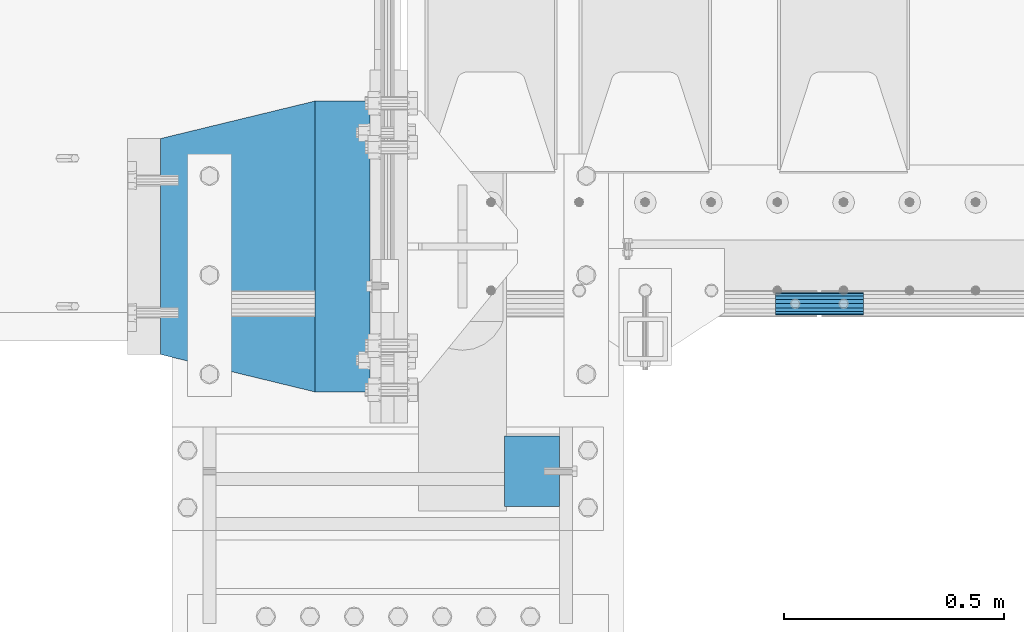
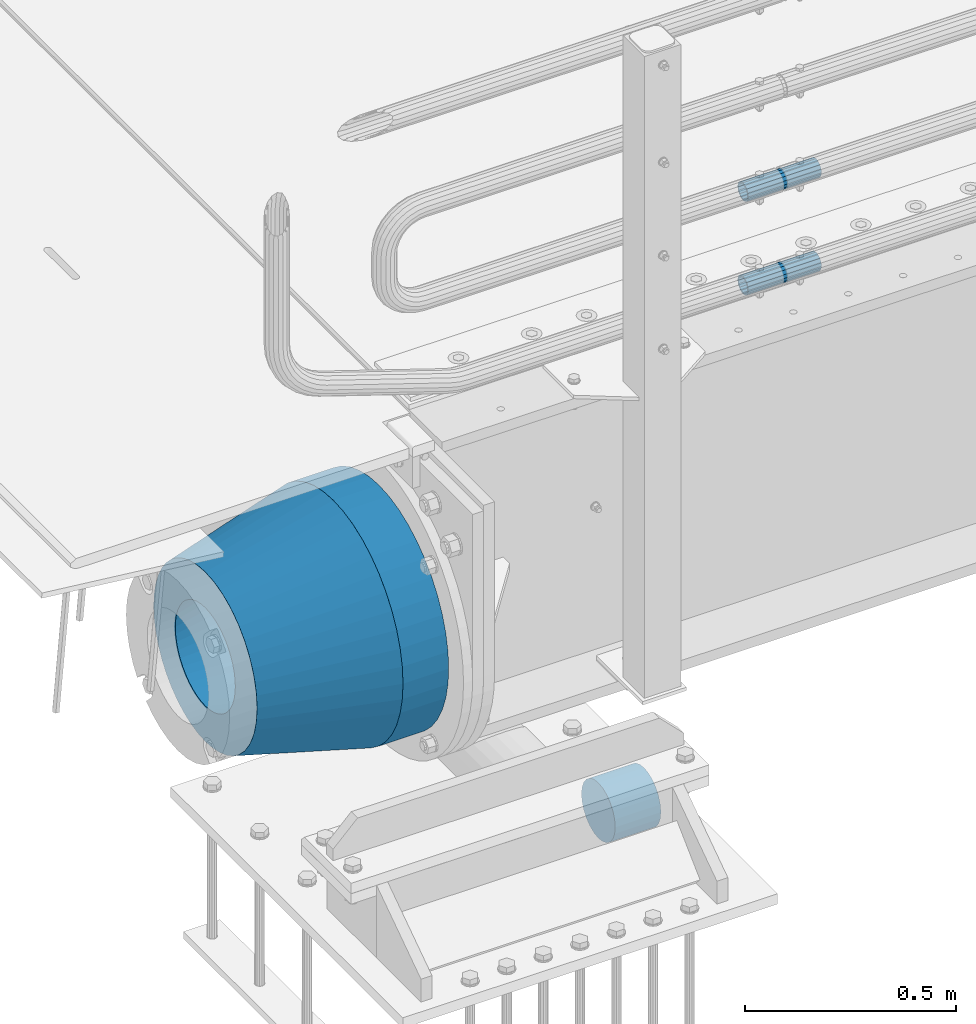
# One storey, part 105 of 193: 5 beams.
"""IFC2X3 building model written with IfcOpenShell, lengths in millimetres."""

import ifcopenshell
import ifcopenshell.guid

model = None  # the IFC model being written
_history = None  # IfcOwnerHistory: only IFC2X3 demands one
_inside = {}  # id of a spatial element -> (the spatial element, [elements in it])
_under = {}  # id of a project, library or spatial element -> (it, [spatial elements below it])
_declared = {}  # id of a project -> (the project, [libraries it declares])
_typed = {}  # id of a type object -> (the type object, [elements of that type])
_made_of = {}  # id of a material, layer set ... -> (it, [elements and type objects made of it])


def new_model(schema):
    """Start an empty IFC model of exactly this schema.

    Asked for "IFC4X3", IfcOpenShell would pick the latest addendum, in which some entities
    have other attributes; the version numbers below select the first issue.
    IFC2X3 requires an IfcOwnerHistory on every rooted entity: one is made here for all.
    """
    global model, _history
    if schema == "IFC4X3":
        model = ifcopenshell.file(schema_version=(4, 3, 0, 0))
    else:
        model = ifcopenshell.file(schema=schema)
    _inside.clear()
    _under.clear()
    _declared.clear()
    _typed.clear()
    _made_of.clear()
    _history = None
    if model.schema == "IFC2X3":
        org = make("IfcOrganization", Name="unknown")
        user = make(
            "IfcPersonAndOrganization",
            ThePerson=make("IfcPerson", FamilyName="unknown"),
            TheOrganization=org,
        )
        app = make(
            "IfcApplication",
            ApplicationDeveloper=org,
            Version="unknown",
            ApplicationFullName="unknown",
            ApplicationIdentifier="unknown",
        )
        _history = make(
            "IfcOwnerHistory",
            OwningUser=user,
            OwningApplication=app,
            ChangeAction="ADDED",
            CreationDate=0,
        )
    return model


def make(cls, **values):
    """One entity of the class cls with the attributes given. An attribute that is None is left unset."""
    return model.create_entity(
        cls, **{name: value for name, value in values.items() if value is not None}
    )


def rooted(cls, **values):
    """An entity with a GlobalId (a new one), such as an element, a storey or a relation."""
    return make(cls, GlobalId=ifcopenshell.guid.new(), OwnerHistory=_history, **values)


def si_unit(unit_type, name, prefix=None):
    """IfcSIUnit, for example si_unit("LENGTHUNIT", "METRE", prefix="MILLI")."""
    return make("IfcSIUnit", UnitType=unit_type, Prefix=prefix, Name=name)


def assignment(units):
    """IfcUnitAssignment: the units of a project."""
    return None if units is None else make("IfcUnitAssignment", Units=units)


def point(xyz):
    """IfcCartesianPoint."""
    return None if xyz is None else make("IfcCartesianPoint", Coordinates=xyz)


def direction(xyz):
    """IfcDirection."""
    return None if xyz is None else make("IfcDirection", DirectionRatios=xyz)


def frame(location, z_axis=None, x_axis=None):
    """IfcAxis2Placement3D, a coordinate frame: its origin and axes. An axis left out is left unset."""
    return make(
        "IfcAxis2Placement3D",
        Location=point(location),
        Axis=direction(z_axis),
        RefDirection=direction(x_axis),
    )


def origin_with_axes():
    """The frame at (0, 0, 0) with the z axis (0, 0, 1) and the x axis (1, 0, 0) written out."""
    return frame((0.0, 0.0, 0.0), z_axis=(0.0, 0.0, 1.0), x_axis=(1.0, 0.0, 0.0))


def place(relative_to, where):
    """IfcLocalPlacement: puts the frame where relative to a parent placement (None: the world)."""
    return make(
        "IfcLocalPlacement", PlacementRelTo=relative_to, RelativePlacement=where
    )


def context(
    kind, dimensions, precision=None, world=None, true_north=None, identifier=None
):
    """IfcGeometricRepresentationContext, for example the 3D "Model" context."""
    return make(
        "IfcGeometricRepresentationContext",
        ContextIdentifier=identifier,
        ContextType=kind,
        CoordinateSpaceDimension=dimensions,
        Precision=precision,
        WorldCoordinateSystem=world,
        TrueNorth=true_north,
    )


def subcontext(parent, identifier, kind, view, scale=None):
    """IfcGeometricRepresentationSubContext, for example "Body" below "Model"."""
    return make(
        "IfcGeometricRepresentationSubContext",
        ContextIdentifier=identifier,
        ContextType=kind,
        ParentContext=parent,
        TargetScale=scale,
        TargetView=view,
    )


def project(units=None, contexts=None):
    """IfcProject with its units and contexts."""
    return rooted(
        "IfcProject",
        Name="project",
        RepresentationContexts=contexts,
        UnitsInContext=assignment(units),
    )


def spatial(cls, under=None, at=None, **own):
    """A site, building, storey or space (cls), placed at a placement, below another one or the project."""
    s = rooted(cls, ObjectPlacement=at, **own)
    if under is not None:
        _under.setdefault(under.id(), (under, []))[1].append(s)
    return s


def faces_of(points, faces, orient=None, outer=None):
    """IfcFace entities. A face is a list of loops; a loop is a list of indices into points, from 0.

    orient and outer hold one flag for each loop. By default every Orientation is true, the
    first loop of a face is its IfcFaceOuterBound and the others are IfcFaceBound.
    """
    made = []
    for i, loops in enumerate(faces):
        bounds = []
        for j, loop in enumerate(loops):
            is_outer = j == 0 if outer is None else outer[i][j]
            bounds.append(
                make(
                    "IfcFaceOuterBound" if is_outer else "IfcFaceBound",
                    Bound=make("IfcPolyLoop", Polygon=[points[k] for k in loop]),
                    Orientation=True if orient is None else orient[i][j],
                )
            )
        made.append(make("IfcFace", Bounds=bounds))
    return made


def faceted_brep(points, faces, orient=None, outer=None, voids=None):
    """IfcFacetedBrep: a solid bounded by flat faces; with voids (closed shells), ...WithVoids."""
    shared = [point(p) for p in points]
    hull = make("IfcClosedShell", CfsFaces=faces_of(shared, faces, orient, outer))
    if voids is None:
        return make("IfcFacetedBrep", Outer=hull)
    return make(
        "IfcFacetedBrepWithVoids",
        Outer=hull,
        Voids=[
            make(cls, CfsFaces=faces_of(shared, fs, o, b)) for cls, fs, o, b in voids
        ],
    )


def shape(context_of_items, identifier, shape_type, items):
    """IfcShapeRepresentation: the items that make up one representation, for example the "Body"."""
    return make(
        "IfcShapeRepresentation",
        ContextOfItems=context_of_items,
        RepresentationIdentifier=identifier,
        RepresentationType=shape_type,
        Items=items,
    )


def material(Name=None, Category=None):
    """IfcMaterial."""
    return make("IfcMaterial", Name=Name, Category=Category)


def made_of(thing, what):
    """Note that an element or type object is made of a material, layer set ...; save() writes the relation."""
    if what is not None:
        _made_of.setdefault(what.id(), (what, []))[1].append(thing)
    return thing


def type_object(cls, material=None, **own):
    """A type object (cls), such as IfcWallType, which elements share."""
    return made_of(rooted(cls, **own), material)


def element(
    cls,
    number,
    at=None,
    inside=None,
    cuts=None,
    type_object=None,
    material=None,
    context=None,
    identifier="Body",
    shape_type=None,
    held_by="IfcProductDefinitionShape",
    body=None,
    shapes=None,
    **own,
):
    """One element of the class cls, such as IfcWall. Its Tag is "e" and its number.

    at: its placement. inside: the storey or other place that contains it. cuts: it is an
    opening in that element (IfcRelVoidsElement). A single representation is given by context,
    identifier, shape_type and body (its items); several are given by shapes. held_by: the class
    of the entity that holds the representations. save() writes the other relations.
    """
    e = rooted(cls, Tag="e%d" % number, ObjectPlacement=at, **own)
    if body is not None:
        shapes = [shape(context, identifier, shape_type, body)]
    if shapes is not None:
        e.Representation = make(held_by, Representations=shapes)
    if inside is not None:
        _inside.setdefault(inside.id(), (inside, []))[1].append(e)
    if cuts is not None:
        rooted(
            "IfcRelVoidsElement", RelatingBuildingElement=cuts, RelatedOpeningElement=e
        )
    if type_object is not None:
        _typed.setdefault(type_object.id(), (type_object, []))[1].append(e)
    return made_of(e, material)


def aggregate(whole, parts):
    """IfcRelAggregates: a whole, such as a stair, and the parts it consists of."""
    return rooted("IfcRelAggregates", RelatingObject=whole, RelatedObjects=parts)


def save(model, path):
    """Write the relations noted so far, then the file.

    IfcRelAggregates (storeys below a building ...), IfcRelContainedInSpatialStructure (elements
    in a storey), IfcRelDefinesByType, IfcRelAssociatesMaterial and IfcRelDeclares: one each for
    every whole, place, type object, material and project.
    """
    for whole, parts in _under.values():
        aggregate(whole, parts)
    for where, things in _inside.values():
        rooted(
            "IfcRelContainedInSpatialStructure",
            RelatedElements=things,
            RelatingStructure=where,
        )
    for kind, things in _typed.values():
        rooted("IfcRelDefinesByType", RelatedObjects=things, RelatingType=kind)
    for what, things in _made_of.values():
        rooted("IfcRelAssociatesMaterial", RelatedObjects=things, RelatingMaterial=what)
    for by, libraries in _declared.values():
        rooted("IfcRelDeclares", RelatingContext=by, RelatedDefinitions=libraries)
    model.write(path)


model = new_model("IFC2X3")

# Units and contexts
model_context = context("Model", 3, precision=1e-05, world=origin_with_axes())
body_context = subcontext(model_context, "Body", "Model", "MODEL_VIEW")
ifc_project = project(units=[si_unit("LENGTHUNIT", "METRE", prefix="MILLI"), si_unit("AREAUNIT", "SQUARE_METRE"), si_unit("VOLUMEUNIT", "CUBIC_METRE"), si_unit("MASSUNIT", "GRAM", prefix="KILO"), si_unit("TIMEUNIT", "SECOND"), si_unit("PLANEANGLEUNIT", "RADIAN"), si_unit("SOLIDANGLEUNIT", "STERADIAN"), si_unit("THERMODYNAMICTEMPERATUREUNIT", "DEGREE_CELSIUS"), si_unit("LUMINOUSINTENSITYUNIT", "LUMEN")], contexts=[model_context])

# Site, building, storey
site_placement = place(None, origin_with_axes())
site = spatial("IfcSite", under=ifc_project, at=site_placement, CompositionType="ELEMENT")
building_placement = place(site_placement, origin_with_axes())
building = spatial("IfcBuilding", under=site, at=building_placement, Name="Standard", CompositionType="ELEMENT")
storey_placement = place(building_placement, origin_with_axes())
storey = spatial("IfcBuildingStorey", under=building, at=storey_placement, Name="Undefined", CompositionType="ELEMENT", Elevation=0.0)

# Beams
ifc_material_1 = material()
beam_type_1 = type_object("IfcBeamType", PredefinedType="NOTDEFINED")
beam_1_placement = place(storey_placement, frame((-42219.9999999991, 23490.000000001, -923.000000000004), z_axis=(0.0, 0.0, -1.0), x_axis=(1.0, 0.0, 0.0)))
element("IfcBeam", 1, at=beam_1_placement, inside=storey, type_object=beam_type_1, material=ifc_material_1, context=body_context, shape_type="Brep", body=[
    faceted_brep([(0.0, -80.0, 0.0), (0.0, -77.2740661031239, -20.7055236082017), (125.0, -77.2740661031239, -20.7055236082017), (125.0, -80.0, 0.0), (0.0, -69.2820323027554, -40.0), (125.0, -69.2820323027554, -40.0), (0.0, -56.5685424949224, -56.5685424949238), (125.0, -56.5685424949224, -56.5685424949238), (0.0, -40.0, -69.2820323027552), (125.0, -40.0, -69.2820323027552), (0.0, -20.7055236082015, -77.2740661031255), (125.0, -20.7055236082015, -77.2740661031255), (0.0, 0.0, -80.0), (125.0, 0.0, -80.0), (0.0, 20.7055236082015, -77.2740661031255), (125.0, 20.7055236082015, -77.2740661031255), (0.0, 40.0, -69.2820323027551), (125.0, 40.0, -69.2820323027551), (0.0, 56.5685424949224, -56.5685424949238), (125.0, 56.5685424949224, -56.5685424949238), (0.0, 69.2820323027554, -40.0), (125.0, 69.2820323027554, -40.0), (0.0, 77.2740661031239, -20.7055236082016), (125.0, 77.2740661031239, -20.7055236082016), (0.0, 80.0, 0.0), (125.0, 80.0, 0.0), (0.0, 77.2740661031239, 20.7055236082017), (125.0, 77.2740661031239, 20.7055236082017), (0.0, 69.2820323027554, 40.0), (125.0, 69.2820323027554, 40.0), (0.0, 56.5685424949224, 56.5685424949238), (125.0, 56.5685424949224, 56.5685424949238), (0.0, 40.0, 69.2820323027551), (125.0, 40.0, 69.2820323027551), (0.0, 20.7055236082015, 77.2740661031255), (125.0, 20.7055236082015, 77.2740661031255), (0.0, 0.0, 80.0), (125.0, 0.0, 80.0), (0.0, -20.7055236082015, 77.2740661031255), (125.0, -20.7055236082015, 77.2740661031255), (0.0, -40.0, 69.2820323027551), (125.0, -40.0, 69.2820323027551), (0.0, -56.5685424949224, 56.5685424949238), (125.0, -56.5685424949224, 56.5685424949238), (0.0, -69.2820323027554, 40.0), (125.0, -69.2820323027554, 40.0), (0.0, -77.2740661031239, 20.7055236082017), (125.0, -77.2740661031239, 20.7055236082017)], [[[0, 1, 2, 3]], [[1, 4, 5, 2]], [[4, 6, 7, 5]], [[6, 8, 9, 7]], [[8, 10, 11, 9]], [[10, 12, 13, 11]], [[12, 14, 15, 13]], [[14, 16, 17, 15]], [[16, 18, 19, 17]], [[18, 20, 21, 19]], [[20, 22, 23, 21]], [[22, 24, 25, 23]], [[24, 26, 27, 25]], [[26, 28, 29, 27]], [[28, 30, 31, 29]], [[30, 32, 33, 31]], [[32, 34, 35, 33]], [[34, 36, 37, 35]], [[36, 38, 39, 37]], [[38, 40, 41, 39]], [[40, 42, 43, 41]], [[42, 44, 45, 43]], [[44, 46, 47, 45]], [[46, 0, 3, 47]], [[5, 7, 9, 11, 13, 15, 17, 19, 21, 23, 25, 27, 29, 31, 33, 35, 37, 39, 41, 43, 45, 47, 3, 2]], [[46, 44, 42, 40, 38, 36, 34, 32, 30, 28, 26, 24, 22, 20, 18, 16, 14, 12, 10, 8, 6, 4, 1, 0]]]),
])
ifc_material_2 = material()
beam_type_2 = type_object("IfcBeamType", PredefinedType="NOTDEFINED")
beam_2_placement = place(storey_placement, frame((-41605.0024970001, 23870.1500000004, 149.849999999747), z_axis=(0.0, 0.0, 1.0), x_axis=(1.0, 0.0, 0.0)))
element("IfcBeam", 2, at=beam_2_placement, inside=storey, type_object=beam_type_2, material=ifc_material_2, context=body_context, shape_type="Brep", body=[
    faceted_brep([(0.0, -21.9000000000015, 0.0), (0.0, -20.232961761998, 8.38076716879547), (200.0, -20.232961761998, 8.38076716879547), (200.0, -21.9000000000015, 0.0), (0.0, -15.4856385079838, 15.4856385079854), (200.0, -15.4856385079838, 15.4856385079854), (0.0, -8.38076716879368, 20.2329617619972), (200.0, -8.38076716879368, 20.2329617619972), (0.0, 0.0, 21.9), (200.0, 0.0, 21.9), (0.0, 8.38076716879368, 20.2329617619972), (200.0, 8.38076716879368, 20.2329617619972), (0.0, 15.4856385079838, 15.4856385079854), (200.0, 15.4856385079838, 15.4856385079854), (0.0, 20.232961761998, 8.38076716879547), (200.0, 20.232961761998, 8.38076716879547), (0.0, 21.9000000000015, 0.0), (200.0, 21.9000000000015, 0.0), (0.0, 20.232961761998, -8.38076716879547), (200.0, 20.232961761998, -8.38076716879547), (0.0, 15.4856385079838, -15.4856385079854), (200.0, 15.4856385079838, -15.4856385079854), (0.0, 8.38076716879368, -20.2329617619972), (200.0, 8.38076716879368, -20.2329617619972), (0.0, 0.0, -21.9), (200.0, 0.0, -21.9), (0.0, -8.38076716879368, -20.2329617619972), (200.0, -8.38076716879368, -20.2329617619972), (0.0, -15.4856385079838, -15.4856385079854), (200.0, -15.4856385079838, -15.4856385079854), (0.0, -20.232961761998, -8.38076716879547), (200.0, -20.232961761998, -8.38076716879547), (0.0, -25.5, 0.0), (0.0, -23.5589280790373, -9.7584275253098), (200.0, -23.5589280790373, -9.7584275253098), (200.0, -25.5, 0.0), (0.0, -18.0312229202573, -18.031222920257), (200.0, -18.0312229202573, -18.031222920257), (0.0, -9.75842752531025, -23.5589280790378), (200.0, -9.75842752531025, -23.5589280790378), (0.0, 0.0, -25.5), (200.0, 0.0, -25.5), (0.0, 9.75842752531025, -23.5589280790378), (200.0, 9.75842752531025, -23.5589280790378), (0.0, 18.0312229202573, -18.031222920257), (200.0, 18.0312229202573, -18.031222920257), (0.0, 23.5589280790373, -9.7584275253098), (200.0, 23.5589280790373, -9.7584275253098), (0.0, 25.5, 0.0), (200.0, 25.5, 0.0), (0.0, 23.5589280790373, 9.7584275253098), (200.0, 23.5589280790373, 9.7584275253098), (0.0, 18.0312229202573, 18.031222920257), (200.0, 18.0312229202573, 18.031222920257), (0.0, 9.75842752531025, 23.5589280790378), (200.0, 9.75842752531025, 23.5589280790378), (0.0, 0.0, 25.5), (200.0, 0.0, 25.5), (0.0, -9.75842752531025, 23.5589280790378), (200.0, -9.75842752531025, 23.5589280790378), (0.0, -18.0312229202573, 18.031222920257), (200.0, -18.0312229202573, 18.031222920257), (0.0, -23.5589280790373, 9.7584275253098), (200.0, -23.5589280790373, 9.7584275253098)], [[[0, 1, 2, 3]], [[1, 4, 5, 2]], [[4, 6, 7, 5]], [[6, 8, 9, 7]], [[8, 10, 11, 9]], [[10, 12, 13, 11]], [[12, 14, 15, 13]], [[14, 16, 17, 15]], [[16, 18, 19, 17]], [[18, 20, 21, 19]], [[20, 22, 23, 21]], [[22, 24, 25, 23]], [[24, 26, 27, 25]], [[26, 28, 29, 27]], [[28, 30, 31, 29]], [[30, 0, 3, 31]], [[32, 33, 34, 35]], [[33, 36, 37, 34]], [[36, 38, 39, 37]], [[38, 40, 41, 39]], [[40, 42, 43, 41]], [[42, 44, 45, 43]], [[44, 46, 47, 45]], [[46, 48, 49, 47]], [[48, 50, 51, 49]], [[50, 52, 53, 51]], [[52, 54, 55, 53]], [[54, 56, 57, 55]], [[56, 58, 59, 57]], [[58, 60, 61, 59]], [[60, 62, 63, 61]], [[62, 32, 35, 63]], [[37, 39, 41, 43, 45, 47, 49, 51, 53, 55, 57, 59, 61, 63, 35, 34], [5, 7, 9, 11, 13, 15, 17, 19, 21, 23, 25, 27, 29, 31, 3, 2]], [[62, 60, 58, 56, 54, 52, 50, 48, 46, 44, 42, 40, 38, 36, 33, 32], [30, 28, 26, 24, 22, 20, 18, 16, 14, 12, 10, 8, 6, 4, 1, 0]]]),
])
beam_3_placement = place(storey_placement, frame((-41605.0024970001, 23870.1500000004, 420.149999999747), z_axis=(0.0, 0.0, 1.0), x_axis=(1.0, 0.0, 0.0)))
element("IfcBeam", 3, at=beam_3_placement, inside=storey, type_object=beam_type_2, material=ifc_material_2, context=body_context, shape_type="Brep", body=[
    faceted_brep([(0.0, -21.9000000000015, 0.0), (0.0, -20.232961761998, 8.38076716879547), (200.0, -20.232961761998, 8.38076716879547), (200.0, -21.9000000000015, 0.0), (0.0, -15.4856385079838, 15.4856385079854), (200.0, -15.4856385079838, 15.4856385079854), (0.0, -8.38076716879368, 20.2329617619972), (200.0, -8.38076716879368, 20.2329617619972), (0.0, 0.0, 21.9), (200.0, 0.0, 21.9), (0.0, 8.38076716879368, 20.2329617619972), (200.0, 8.38076716879368, 20.2329617619972), (0.0, 15.4856385079838, 15.4856385079854), (200.0, 15.4856385079838, 15.4856385079854), (0.0, 20.232961761998, 8.38076716879547), (200.0, 20.232961761998, 8.38076716879547), (0.0, 21.9000000000015, 0.0), (200.0, 21.9000000000015, 0.0), (0.0, 20.232961761998, -8.38076716879547), (200.0, 20.232961761998, -8.38076716879547), (0.0, 15.4856385079838, -15.4856385079854), (200.0, 15.4856385079838, -15.4856385079854), (0.0, 8.38076716879368, -20.2329617619972), (200.0, 8.38076716879368, -20.2329617619972), (0.0, 0.0, -21.9), (200.0, 0.0, -21.9), (0.0, -8.38076716879368, -20.2329617619972), (200.0, -8.38076716879368, -20.2329617619972), (0.0, -15.4856385079838, -15.4856385079854), (200.0, -15.4856385079838, -15.4856385079854), (0.0, -20.232961761998, -8.38076716879547), (200.0, -20.232961761998, -8.38076716879547), (0.0, -25.5, 0.0), (0.0, -23.5589280790373, -9.7584275253098), (200.0, -23.5589280790373, -9.7584275253098), (200.0, -25.5, 0.0), (0.0, -18.0312229202573, -18.031222920257), (200.0, -18.0312229202573, -18.031222920257), (0.0, -9.75842752531025, -23.5589280790378), (200.0, -9.75842752531025, -23.5589280790378), (0.0, 0.0, -25.5), (200.0, 0.0, -25.5), (0.0, 9.75842752531025, -23.5589280790378), (200.0, 9.75842752531025, -23.5589280790378), (0.0, 18.0312229202573, -18.031222920257), (200.0, 18.0312229202573, -18.031222920257), (0.0, 23.5589280790373, -9.7584275253098), (200.0, 23.5589280790373, -9.7584275253098), (0.0, 25.5, 0.0), (200.0, 25.5, 0.0), (0.0, 23.5589280790373, 9.7584275253098), (200.0, 23.5589280790373, 9.7584275253098), (0.0, 18.0312229202573, 18.031222920257), (200.0, 18.0312229202573, 18.031222920257), (0.0, 9.75842752531025, 23.5589280790378), (200.0, 9.75842752531025, 23.5589280790378), (0.0, 0.0, 25.5), (200.0, 0.0, 25.5), (0.0, -9.75842752531025, 23.5589280790378), (200.0, -9.75842752531025, 23.5589280790378), (0.0, -18.0312229202573, 18.031222920257), (200.0, -18.0312229202573, 18.031222920257), (0.0, -23.5589280790373, 9.7584275253098), (200.0, -23.5589280790373, 9.7584275253098)], [[[0, 1, 2, 3]], [[1, 4, 5, 2]], [[4, 6, 7, 5]], [[6, 8, 9, 7]], [[8, 10, 11, 9]], [[10, 12, 13, 11]], [[12, 14, 15, 13]], [[14, 16, 17, 15]], [[16, 18, 19, 17]], [[18, 20, 21, 19]], [[20, 22, 23, 21]], [[22, 24, 25, 23]], [[24, 26, 27, 25]], [[26, 28, 29, 27]], [[28, 30, 31, 29]], [[30, 0, 3, 31]], [[32, 33, 34, 35]], [[33, 36, 37, 34]], [[36, 38, 39, 37]], [[38, 40, 41, 39]], [[40, 42, 43, 41]], [[42, 44, 45, 43]], [[44, 46, 47, 45]], [[46, 48, 49, 47]], [[48, 50, 51, 49]], [[50, 52, 53, 51]], [[52, 54, 55, 53]], [[54, 56, 57, 55]], [[56, 58, 59, 57]], [[58, 60, 61, 59]], [[60, 62, 63, 61]], [[62, 32, 35, 63]], [[37, 39, 41, 43, 45, 47, 49, 51, 53, 55, 57, 59, 61, 63, 35, 34], [5, 7, 9, 11, 13, 15, 17, 19, 21, 23, 25, 27, 29, 31, 3, 2]], [[62, 60, 58, 56, 54, 52, 50, 48, 46, 44, 42, 40, 38, 36, 33, 32], [30, 28, 26, 24, 22, 20, 18, 16, 14, 12, 10, 8, 6, 4, 1, 0]]]),
])
ifc_material_3 = material(Name="STEEL/S355N")
beam_type_3 = type_object("IfcBeamType", PredefinedType="NOTDEFINED")
beam_4_placement = place(storey_placement, frame((-42525.0, 24000.0, -515.0), z_axis=(0.0, 0.0, 1.0), x_axis=(-1.0, 0.0, 0.0)))
element("IfcBeam", 4, at=beam_4_placement, inside=storey, type_object=beam_type_3, material=ifc_material_3, context=body_context, shape_type="Brep", body=[
    faceted_brep([(0.0, -215.0, 0.0), (0.0, -212.811610004399, 30.5976902287563), (125.0, -212.811610004399, 30.5976902287563), (125.0, -215.0, 0.0), (0.0, -206.290989327117, 60.5724997209074), (125.0, -206.290989327117, 60.5724997209074), (0.0, -195.570879001221, 89.3142277954056), (125.0, -195.570879001221, 89.3142277954056), (0.0, -180.869509558703, 116.237775752953), (125.0, -180.869509558703, 116.237775752953), (0.0, -162.486158486165, 140.795057798236), (125.0, -162.486158486165, 140.795057798236), (0.0, -140.795057798237, 162.486158486165), (125.0, -140.795057798237, 162.486158486165), (0.0, -116.237775752954, 180.869509558704), (125.0, -116.237775752954, 180.869509558704), (0.0, -89.3142277954066, 195.570879001222), (125.0, -89.3142277954066, 195.570879001222), (0.0, -60.5724997209072, 206.290989327117), (125.0, -60.5724997209072, 206.290989327117), (0.0, -30.5976902287548, 212.811610004401), (125.0, -30.5976902287548, 212.811610004401), (0.0, 0.0, 215.0), (125.0, 0.0, 215.0), (0.0, 30.5976902287548, 212.811610004401), (125.0, 30.5976902287548, 212.811610004401), (0.0, 60.5724997209072, 206.290989327117), (125.0, 60.5724997209072, 206.290989327117), (0.0, 89.3142277954066, 195.570879001221), (125.0, 89.3142277954066, 195.570879001221), (0.0, 116.237775752954, 180.869509558704), (125.0, 116.237775752954, 180.869509558704), (0.0, 140.795057798237, 162.486158486165), (125.0, 140.795057798237, 162.486158486165), (0.0, 162.486158486165, 140.795057798236), (125.0, 162.486158486165, 140.795057798236), (0.0, 180.869509558703, 116.237775752953), (125.0, 180.869509558703, 116.237775752953), (0.0, 195.570879001221, 89.3142277954056), (125.0, 195.570879001221, 89.3142277954056), (0.0, 206.290989327117, 60.5724997209073), (125.0, 206.290989327117, 60.5724997209073), (0.0, 212.811610004399, 30.5976902287563), (125.0, 212.811610004399, 30.5976902287563), (0.0, 215.0, 0.0), (125.0, 215.0, 0.0), (0.0, 212.811610004399, -30.5976902287563), (125.0, 212.811610004399, -30.5976902287563), (0.0, 206.290989327117, -60.5724997209073), (125.0, 206.290989327117, -60.5724997209073), (0.0, 195.570879001221, -89.3142277954056), (125.0, 195.570879001221, -89.3142277954056), (0.0, 180.869509558703, -116.237775752954), (125.0, 180.869509558703, -116.237775752954), (0.0, 162.486158486165, -140.795057798236), (125.0, 162.486158486165, -140.795057798236), (0.0, 140.795057798237, -162.486158486166), (125.0, 140.795057798237, -162.486158486166), (0.0, 116.237775752954, -180.869509558704), (125.0, 116.237775752954, -180.869509558704), (0.0, 89.3142277954066, -195.570879001221), (125.0, 89.3142277954066, -195.570879001221), (0.0, 60.5724997209072, -206.290989327117), (125.0, 60.5724997209072, -206.290989327117), (0.0, 30.5976902287548, -212.811610004401), (125.0, 30.5976902287548, -212.811610004401), (0.0, 0.0, -215.0), (125.0, 0.0, -215.0), (0.0, -30.5976902287548, -212.811610004401), (125.0, -30.5976902287548, -212.811610004401), (0.0, -60.5724997209072, -206.290989327117), (125.0, -60.5724997209072, -206.290989327117), (0.0, -89.3142277954066, -195.570879001221), (125.0, -89.3142277954066, -195.570879001221), (0.0, -116.237775752954, -180.869509558704), (125.0, -116.237775752954, -180.869509558704), (0.0, -140.795057798237, -162.486158486166), (125.0, -140.795057798237, -162.486158486166), (0.0, -162.486158486165, -140.795057798236), (125.0, -162.486158486165, -140.795057798236), (0.0, -180.869509558703, -116.237775752953), (125.0, -180.869509558703, -116.237775752953), (0.0, -195.570879001221, -89.3142277954056), (125.0, -195.570879001221, -89.3142277954056), (0.0, -206.290989327117, -60.5724997209073), (125.0, -206.290989327117, -60.5724997209073), (0.0, -212.811610004399, -30.5976902287563), (125.0, -212.811610004399, -30.5976902287563), (0.0, -330.0, 0.0), (0.0, -326.641075820709, -46.9638966301842), (125.0, -326.641075820709, -46.9638966301842), (125.0, -330.0, 0.0), (0.0, -316.632681292784, -92.9717437576718), (125.0, -316.632681292784, -92.9717437576718), (0.0, -300.178558466992, -137.086954290623), (125.0, -300.178558466992, -137.086954290623), (0.0, -277.613665834291, -178.411469760347), (125.0, -277.613665834291, -178.411469760347), (0.0, -249.397359536906, -216.104042201944), (125.0, -249.397359536906, -216.104042201944), (0.0, -216.104042201943, -249.397359536905), (125.0, -216.104042201943, -249.397359536905), (0.0, -178.411469760347, -277.61366583429), (125.0, -178.411469760347, -277.61366583429), (0.0, -137.086954290622, -300.178558466991), (125.0, -137.086954290622, -300.178558466991), (0.0, -92.9717437576728, -316.632681292784), (125.0, -92.9717437576728, -316.632681292784), (0.0, -46.9638966301827, -326.641075820708), (125.0, -46.9638966301827, -326.641075820708), (0.0, 0.0, -330.0), (125.0, 0.0, -330.0), (0.0, 46.9638966301827, -326.641075820708), (125.0, 46.9638966301827, -326.641075820708), (0.0, 92.9717437576728, -316.632681292784), (125.0, 92.9717437576728, -316.632681292784), (0.0, 137.086954290622, -300.178558466991), (125.0, 137.086954290622, -300.178558466991), (0.0, 178.411469760347, -277.61366583429), (125.0, 178.411469760347, -277.61366583429), (0.0, 216.104042201943, -249.397359536905), (125.0, 216.104042201943, -249.397359536905), (0.0, 249.397359536906, -216.104042201944), (125.0, 249.397359536906, -216.104042201944), (0.0, 277.613665834291, -178.411469760347), (125.0, 277.613665834291, -178.411469760347), (0.0, 300.178558466992, -137.086954290623), (125.0, 300.178558466992, -137.086954290623), (0.0, 316.632681292784, -92.9717437576717), (125.0, 316.632681292784, -92.9717437576717), (0.0, 326.641075820709, -46.9638966301841), (125.0, 326.641075820709, -46.9638966301841), (0.0, 330.0, 0.0), (125.0, 330.0, 0.0), (0.0, 326.641075820709, 46.9638966301841), (125.0, 326.641075820709, 46.9638966301841), (0.0, 316.632681292784, 92.9717437576718), (125.0, 316.632681292784, 92.9717437576718), (0.0, 300.178558466992, 137.086954290622), (125.0, 300.178558466992, 137.086954290622), (0.0, 277.613665834291, 178.411469760347), (125.0, 277.613665834291, 178.411469760347), (0.0, 249.397359536906, 216.104042201944), (125.0, 249.397359536906, 216.104042201944), (0.0, 216.104042201943, 249.397359536905), (125.0, 216.104042201943, 249.397359536905), (0.0, 178.411469760347, 277.61366583429), (125.0, 178.411469760347, 277.61366583429), (0.0, 137.086954290622, 300.178558466991), (125.0, 137.086954290622, 300.178558466991), (0.0, 92.9717437576728, 316.632681292784), (125.0, 92.9717437576728, 316.632681292784), (0.0, 46.9638966301827, 326.641075820708), (125.0, 46.9638966301827, 326.641075820708), (0.0, 0.0, 330.0), (125.0, 0.0, 330.0), (0.0, -46.9638966301827, 326.641075820708), (125.0, -46.9638966301827, 326.641075820708), (0.0, -92.9717437576728, 316.632681292784), (125.0, -92.9717437576728, 316.632681292784), (0.0, -137.086954290622, 300.178558466991), (125.0, -137.086954290622, 300.178558466991), (0.0, -178.411469760347, 277.61366583429), (125.0, -178.411469760347, 277.61366583429), (0.0, -216.104042201943, 249.397359536905), (125.0, -216.104042201943, 249.397359536905), (0.0, -249.397359536906, 216.104042201944), (125.0, -249.397359536906, 216.104042201944), (0.0, -277.613665834291, 178.411469760347), (125.0, -277.613665834291, 178.411469760347), (0.0, -300.178558466992, 137.086954290623), (125.0, -300.178558466992, 137.086954290623), (0.0, -316.632681292784, 92.9717437576718), (125.0, -316.632681292784, 92.9717437576718), (0.0, -326.641075820709, 46.9638966301841), (125.0, -326.641075820709, 46.9638966301841)], [[[0, 1, 2, 3]], [[1, 4, 5, 2]], [[4, 6, 7, 5]], [[6, 8, 9, 7]], [[8, 10, 11, 9]], [[10, 12, 13, 11]], [[12, 14, 15, 13]], [[14, 16, 17, 15]], [[16, 18, 19, 17]], [[18, 20, 21, 19]], [[20, 22, 23, 21]], [[22, 24, 25, 23]], [[24, 26, 27, 25]], [[26, 28, 29, 27]], [[28, 30, 31, 29]], [[30, 32, 33, 31]], [[32, 34, 35, 33]], [[34, 36, 37, 35]], [[36, 38, 39, 37]], [[38, 40, 41, 39]], [[40, 42, 43, 41]], [[42, 44, 45, 43]], [[44, 46, 47, 45]], [[46, 48, 49, 47]], [[48, 50, 51, 49]], [[50, 52, 53, 51]], [[52, 54, 55, 53]], [[54, 56, 57, 55]], [[56, 58, 59, 57]], [[58, 60, 61, 59]], [[60, 62, 63, 61]], [[62, 64, 65, 63]], [[64, 66, 67, 65]], [[66, 68, 69, 67]], [[68, 70, 71, 69]], [[70, 72, 73, 71]], [[72, 74, 75, 73]], [[74, 76, 77, 75]], [[76, 78, 79, 77]], [[78, 80, 81, 79]], [[80, 82, 83, 81]], [[82, 84, 85, 83]], [[84, 86, 87, 85]], [[86, 0, 3, 87]], [[88, 89, 90, 91]], [[89, 92, 93, 90]], [[92, 94, 95, 93]], [[94, 96, 97, 95]], [[96, 98, 99, 97]], [[98, 100, 101, 99]], [[100, 102, 103, 101]], [[102, 104, 105, 103]], [[104, 106, 107, 105]], [[106, 108, 109, 107]], [[108, 110, 111, 109]], [[110, 112, 113, 111]], [[112, 114, 115, 113]], [[114, 116, 117, 115]], [[116, 118, 119, 117]], [[118, 120, 121, 119]], [[120, 122, 123, 121]], [[122, 124, 125, 123]], [[124, 126, 127, 125]], [[126, 128, 129, 127]], [[128, 130, 131, 129]], [[130, 132, 133, 131]], [[132, 134, 135, 133]], [[134, 136, 137, 135]], [[136, 138, 139, 137]], [[138, 140, 141, 139]], [[140, 142, 143, 141]], [[142, 144, 145, 143]], [[144, 146, 147, 145]], [[146, 148, 149, 147]], [[148, 150, 151, 149]], [[150, 152, 153, 151]], [[152, 154, 155, 153]], [[154, 156, 157, 155]], [[156, 158, 159, 157]], [[158, 160, 161, 159]], [[160, 162, 163, 161]], [[162, 164, 165, 163]], [[164, 166, 167, 165]], [[166, 168, 169, 167]], [[168, 170, 171, 169]], [[170, 172, 173, 171]], [[172, 174, 175, 173]], [[174, 88, 91, 175]], [[93, 95, 97, 99, 101, 103, 105, 107, 109, 111, 113, 115, 117, 119, 121, 123, 125, 127, 129, 131, 133, 135, 137, 139, 141, 143, 145, 147, 149, 151, 153, 155, 157, 159, 161, 163, 165, 167, 169, 171, 173, 175, 91, 90], [5, 7, 9, 11, 13, 15, 17, 19, 21, 23, 25, 27, 29, 31, 33, 35, 37, 39, 41, 43, 45, 47, 49, 51, 53, 55, 57, 59, 61, 63, 65, 67, 69, 71, 73, 75, 77, 79, 81, 83, 85, 87, 3, 2]], [[174, 172, 170, 168, 166, 164, 162, 160, 158, 156, 154, 152, 150, 148, 146, 144, 142, 140, 138, 136, 134, 132, 130, 128, 126, 124, 122, 120, 118, 116, 114, 112, 110, 108, 106, 104, 102, 100, 98, 96, 94, 92, 89, 88], [86, 84, 82, 80, 78, 76, 74, 72, 70, 68, 66, 64, 62, 60, 58, 56, 54, 52, 50, 48, 46, 44, 42, 40, 38, 36, 34, 32, 30, 28, 26, 24, 22, 20, 18, 16, 14, 12, 10, 8, 6, 4, 1, 0]]]),
])
ifc_material_4 = material(Name="SCN-500-E2")
beam_type_4 = type_object("IfcBeamType", PredefinedType="NOTDEFINED")
beam_5_placement = place(storey_placement, frame((-42650.0, 24000.0, -515.0), z_axis=(0.0, 0.0, 1.0), x_axis=(-1.0, 0.0, 0.0)))
element("IfcBeam", 5, at=beam_5_placement, inside=storey, type_object=beam_type_4, material=ifc_material_4, context=body_context, shape_type="Brep", body=[
    faceted_brep([(0.0, -330.0, 0.0), (0.0, -326.641075820709, -46.9638966301842), (350.0, -242.506253260828, -34.8671353769549), (350.0, -245.0, 0.0), (0.0, -316.632681292784, -92.9717437576718), (350.0, -235.075778535553, -69.0244764261503), (0.0, -300.178558466992, -137.086954290623), (350.0, -222.859838861856, -101.776678185462), (0.0, -277.613665834291, -178.411469760347), (350.0, -206.10711554364, -132.457000276621), (0.0, -249.397359536906, -216.104042201944), (350.0, -185.158645716794, -160.440879816595), (0.0, -216.104042201943, -249.397359536905), (350.0, -160.440879816593, -185.158645716793), (0.0, -178.411469760347, -277.61366583429), (350.0, -132.45700027662, -206.107115543639), (0.0, -137.086954290622, -300.178558466991), (350.0, -101.776678185463, -222.859838861857), (0.0, -92.9717437576728, -316.632681292784), (350.0, -69.0244764261515, -235.075778535552), (0.0, -46.9638966301827, -326.641075820708), (350.0, -34.8671353769532, -242.506253260829), (0.0, 0.0, -330.0), (350.0, 0.0, -245.0), (0.0, 46.9638966301827, -326.641075820708), (350.0, 34.8671353769532, -242.506253260829), (0.0, 92.9717437576728, -316.632681292784), (350.0, 69.0244764261515, -235.075778535552), (0.0, 137.086954290622, -300.178558466991), (350.0, 101.776678185463, -222.859838861857), (0.0, 178.411469760347, -277.61366583429), (350.0, 132.457000276623, -206.107115543639), (0.0, 216.104042201943, -249.397359536905), (350.0, 160.440879816593, -185.158645716793), (0.0, 249.397359536906, -216.104042201944), (350.0, 185.158645716794, -160.440879816595), (0.0, 277.613665834291, -178.411469760347), (350.0, 206.10711554364, -132.457000276621), (0.0, 300.178558466992, -137.086954290623), (350.0, 222.859838861856, -101.776678185462), (0.0, 316.632681292784, -92.9717437576717), (350.0, 235.075778535553, -69.0244764261502), (0.0, 326.641075820709, -46.9638966301841), (350.0, 242.506253260828, -34.8671353769548), (0.0, 330.0, 0.0), (350.0, 245.0, 0.0), (0.0, 326.641075820709, 46.9638966301841), (350.0, 242.506253260828, 34.8671353769549), (0.0, 316.632681292784, 92.9717437576718), (350.0, 235.075778535553, 69.0244764261503), (0.0, 300.178558466992, 137.086954290622), (350.0, 222.859838861856, 101.776678185462), (0.0, 277.613665834291, 178.411469760347), (350.0, 206.10711554364, 132.457000276621), (0.0, 249.397359536906, 216.104042201944), (350.0, 185.158645716794, 160.440879816595), (0.0, 216.104042201943, 249.397359536905), (350.0, 160.440879816593, 185.158645716793), (0.0, 178.411469760347, 277.61366583429), (350.0, 132.457000276623, 206.107115543639), (0.0, 137.086954290622, 300.178558466991), (350.0, 101.776678185463, 222.859838861857), (0.0, 92.9717437576728, 316.632681292784), (350.0, 69.0244764261515, 235.075778535552), (0.0, 46.9638966301827, 326.641075820708), (350.0, 34.8671353769532, 242.506253260829), (0.0, 0.0, 330.0), (350.0, 0.0, 245.0), (0.0, -46.9638966301827, 326.641075820708), (350.0, -34.8671353769532, 242.506253260829), (0.0, -92.9717437576728, 316.632681292784), (350.0, -69.0244764261515, 235.075778535552), (0.0, -137.086954290622, 300.178558466991), (350.0, -101.776678185463, 222.859838861857), (0.0, -178.411469760347, 277.61366583429), (350.0, -132.457000276623, 206.107115543639), (0.0, -216.104042201943, 249.397359536905), (350.0, -160.440879816593, 185.158645716793), (0.0, -249.397359536906, 216.104042201944), (350.0, -185.158645716794, 160.440879816595), (0.0, -277.613665834291, 178.411469760347), (350.0, -206.10711554364, 132.457000276621), (0.0, -300.178558466992, 137.086954290623), (350.0, -222.859838861856, 101.776678185462), (0.0, -316.632681292784, 92.9717437576718), (350.0, -235.075778535553, 69.0244764261503), (0.0, -326.641075820709, 46.9638966301841), (350.0, -242.506253260828, 34.8671353769549), (0.0, -227.093265923133, 0.0), (0.0, -224.781783917482, 32.3187414128026), (350.0, -140.646961357605, 20.2219801595734), (350.0, -142.093265923133, 0.0), (0.0, -217.894393008413, 63.9795664499945), (350.0, -136.337490251182, 40.032299118473), (0.0, -206.571300613232, 94.3379520160985), (350.0, -129.252581008099, 59.0276759109381), (0.0, -191.043012240007, 122.775888927343), (350.0, -119.536461949356, 76.8214194436173), (0.0, -171.625639060127, 148.714462796454), (350.0, -107.386925240015, 93.0513004111044), (0.0, -148.714462796455, 171.625639060125), (350.0, -93.0513004111053, 107.386925240013), (0.0, -122.775888927343, 191.043012240005), (350.0, -76.8214194436187, 119.536461949355), (0.0, -94.3379520160997, 206.571300613232), (350.0, -59.0276759109365, 129.252581008098), (0.0, -63.9795664499943, 217.894393008413), (350.0, -40.032299118473, 136.337490251181), (0.0, -32.3187414128042, 224.781783917484), (350.0, -20.2219801595747, 140.646961357605), (0.0, 0.0, 227.093265923131), (350.0, 0.0, 142.093265923131), (0.0, 32.3187414128042, 224.781783917484), (350.0, 20.2219801595747, 140.646961357605), (0.0, 63.9795664499943, 217.894393008413), (350.0, 40.032299118473, 136.337490251181), (0.0, 94.3379520160997, 206.571300613232), (350.0, 59.0276759109365, 129.252581008098), (0.0, 122.775888927343, 191.043012240005), (350.0, 76.8214194436187, 119.536461949355), (0.0, 148.714462796455, 171.625639060125), (350.0, 93.0513004111053, 107.386925240013), (0.0, 171.625639060127, 148.714462796454), (350.0, 107.386925240015, 93.0513004111044), (0.0, 191.043012240007, 122.775888927343), (350.0, 119.536461949356, 76.8214194436174), (0.0, 206.571300613232, 94.3379520160985), (350.0, 129.252581008099, 59.0276759109382), (0.0, 217.894393008413, 63.9795664499945), (350.0, 136.337490251182, 40.032299118473), (0.0, 224.781783917482, 32.3187414128025), (350.0, 140.646961357605, 20.2219801595733), (0.0, 227.093265923133, 0.0), (350.0, 142.093265923133, 0.0), (0.0, 224.781783917482, -32.3187414128026), (350.0, 140.646961357605, -20.2219801595734), (0.0, 217.894393008413, -63.9795664499945), (350.0, 136.337490251182, -40.032299118473), (0.0, 206.571300613232, -94.3379520160985), (350.0, 129.252581008099, -59.0276759109381), (0.0, 191.043012240007, -122.775888927343), (350.0, 119.536461949356, -76.8214194436174), (0.0, 171.625639060127, -148.714462796454), (350.0, 107.386925240015, -93.0513004111044), (0.0, 148.714462796455, -171.625639060125), (350.0, 93.0513004111053, -107.386925240013), (0.0, 122.775888927343, -191.043012240005), (350.0, 76.8214194436187, -119.536461949355), (0.0, 94.3379520160997, -206.571300613232), (350.0, 59.0276759109365, -129.252581008098), (0.0, 63.9795664499943, -217.894393008413), (350.0, 40.032299118473, -136.337490251181), (0.0, 32.3187414128042, -224.781783917484), (350.0, 20.2219801595747, -140.646961357605), (0.0, 0.0, -227.093265923131), (350.0, 0.0, -142.093265923131), (0.0, -32.3187414128042, -224.781783917484), (350.0, -20.2219801595747, -140.646961357605), (0.0, -63.9795664499943, -217.894393008413), (350.0, -40.032299118473, -136.337490251181), (0.0, -94.3379520160997, -206.571300613232), (350.0, -59.0276759109365, -129.252581008098), (0.0, -122.775888927343, -191.043012240005), (350.0, -76.8214194436187, -119.536461949355), (0.0, -148.714462796455, -171.625639060125), (350.0, -93.0513004111053, -107.386925240013), (0.0, -171.625639060127, -148.714462796454), (350.0, -107.386925240015, -93.0513004111044), (0.0, -191.043012240007, -122.775888927343), (350.0, -119.536461949356, -76.8214194436174), (0.0, -206.571300613232, -94.3379520160985), (350.0, -129.252581008099, -59.0276759109381), (0.0, -217.894393008413, -63.9795664499945), (350.0, -136.337490251182, -40.032299118473), (0.0, -224.781783917482, -32.3187414128026), (350.0, -140.646961357605, -20.2219801595734)], [[[0, 1, 2, 3]], [[1, 4, 5, 2]], [[4, 6, 7, 5]], [[6, 8, 9, 7]], [[8, 10, 11, 9]], [[10, 12, 13, 11]], [[12, 14, 15, 13]], [[14, 16, 17, 15]], [[16, 18, 19, 17]], [[18, 20, 21, 19]], [[20, 22, 23, 21]], [[22, 24, 25, 23]], [[24, 26, 27, 25]], [[26, 28, 29, 27]], [[28, 30, 31, 29]], [[30, 32, 33, 31]], [[32, 34, 35, 33]], [[34, 36, 37, 35]], [[36, 38, 39, 37]], [[38, 40, 41, 39]], [[40, 42, 43, 41]], [[42, 44, 45, 43]], [[44, 46, 47, 45]], [[46, 48, 49, 47]], [[48, 50, 51, 49]], [[50, 52, 53, 51]], [[52, 54, 55, 53]], [[54, 56, 57, 55]], [[56, 58, 59, 57]], [[58, 60, 61, 59]], [[60, 62, 63, 61]], [[62, 64, 65, 63]], [[64, 66, 67, 65]], [[66, 68, 69, 67]], [[68, 70, 71, 69]], [[70, 72, 73, 71]], [[72, 74, 75, 73]], [[74, 76, 77, 75]], [[76, 78, 79, 77]], [[78, 80, 81, 79]], [[80, 82, 83, 81]], [[82, 84, 85, 83]], [[84, 86, 87, 85]], [[86, 0, 3, 87]], [[88, 89, 90, 91]], [[89, 92, 93, 90]], [[92, 94, 95, 93]], [[94, 96, 97, 95]], [[96, 98, 99, 97]], [[98, 100, 101, 99]], [[100, 102, 103, 101]], [[102, 104, 105, 103]], [[104, 106, 107, 105]], [[106, 108, 109, 107]], [[108, 110, 111, 109]], [[110, 112, 113, 111]], [[112, 114, 115, 113]], [[114, 116, 117, 115]], [[116, 118, 119, 117]], [[118, 120, 121, 119]], [[120, 122, 123, 121]], [[122, 124, 125, 123]], [[124, 126, 127, 125]], [[126, 128, 129, 127]], [[128, 130, 131, 129]], [[130, 132, 133, 131]], [[132, 134, 135, 133]], [[134, 136, 137, 135]], [[136, 138, 139, 137]], [[138, 140, 141, 139]], [[140, 142, 143, 141]], [[142, 144, 145, 143]], [[144, 146, 147, 145]], [[146, 148, 149, 147]], [[148, 150, 151, 149]], [[150, 152, 153, 151]], [[152, 154, 155, 153]], [[154, 156, 157, 155]], [[156, 158, 159, 157]], [[158, 160, 161, 159]], [[160, 162, 163, 161]], [[162, 164, 165, 163]], [[164, 166, 167, 165]], [[166, 168, 169, 167]], [[168, 170, 171, 169]], [[170, 172, 173, 171]], [[172, 174, 175, 173]], [[174, 88, 91, 175]], [[5, 7, 9, 11, 13, 15, 17, 19, 21, 23, 25, 27, 29, 31, 33, 35, 37, 39, 41, 43, 45, 47, 49, 51, 53, 55, 57, 59, 61, 63, 65, 67, 69, 71, 73, 75, 77, 79, 81, 83, 85, 87, 3, 2], [93, 95, 97, 99, 101, 103, 105, 107, 109, 111, 113, 115, 117, 119, 121, 123, 125, 127, 129, 131, 133, 135, 137, 139, 141, 143, 145, 147, 149, 151, 153, 155, 157, 159, 161, 163, 165, 167, 169, 171, 173, 175, 91, 90]], [[86, 84, 82, 80, 78, 76, 74, 72, 70, 68, 66, 64, 62, 60, 58, 56, 54, 52, 50, 48, 46, 44, 42, 40, 38, 36, 34, 32, 30, 28, 26, 24, 22, 20, 18, 16, 14, 12, 10, 8, 6, 4, 1, 0], [174, 172, 170, 168, 166, 164, 162, 160, 158, 156, 154, 152, 150, 148, 146, 144, 142, 140, 138, 136, 134, 132, 130, 128, 126, 124, 122, 120, 118, 116, 114, 112, 110, 108, 106, 104, 102, 100, 98, 96, 94, 92, 89, 88]]]),
])

save(model, "model.ifc")
